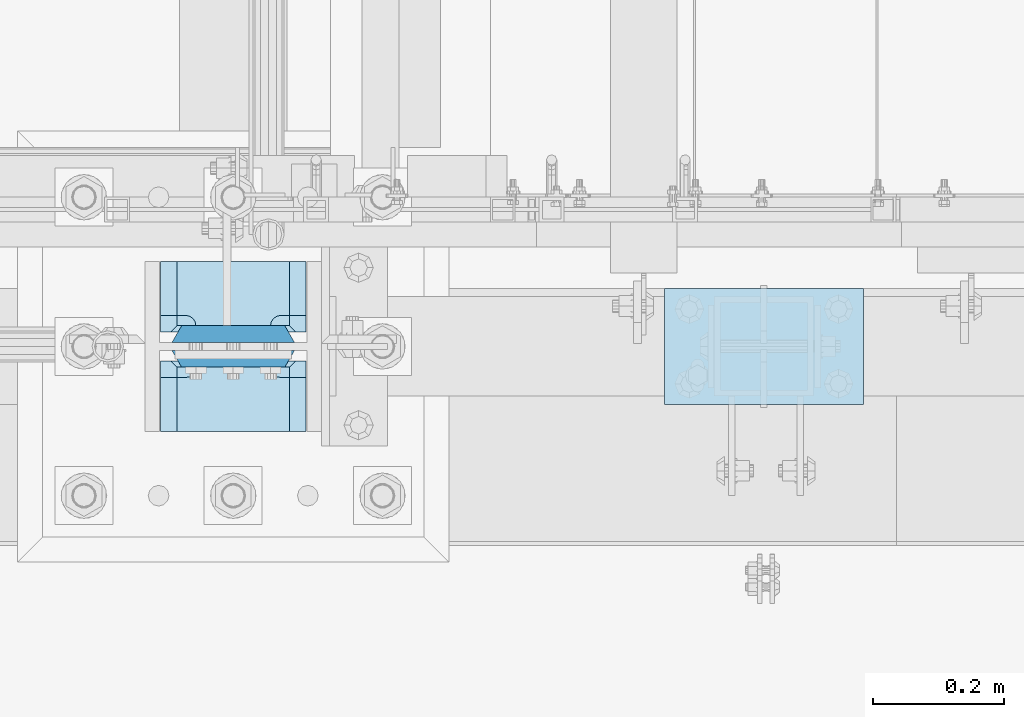
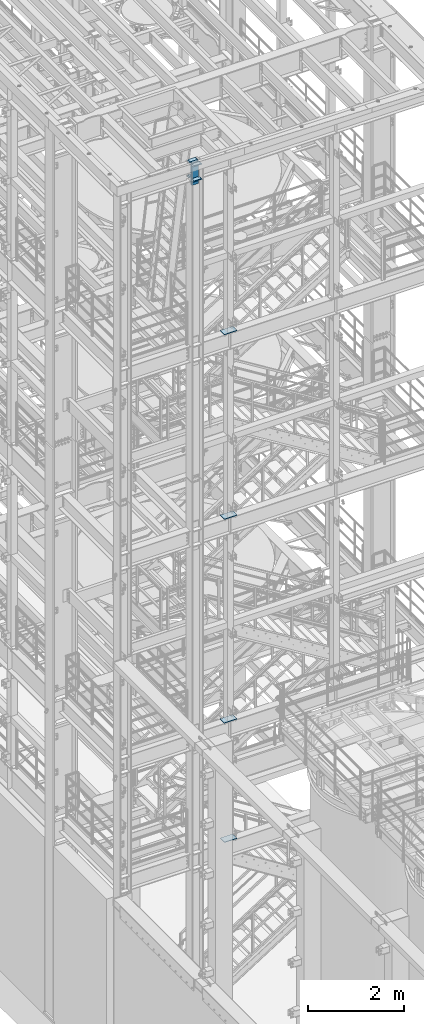
# One storey, part 1432 of 1876: 10 plates, 5 elements without a shape of their own.
"""IFC2X3 building model written with IfcOpenShell, lengths in millimetres."""

from ifc_helpers import new_model, si_unit, frame, origin_with_axes, place, context, subcontext, project, spatial, faceted_brep, material, type_object, element, aggregate, save


model = new_model("IFC2X3")

# Units and contexts
model_context = context("Model", 3, precision=1e-05, world=origin_with_axes())
body_context = subcontext(model_context, "Body", "Model", "MODEL_VIEW")
ifc_project = project(units=[si_unit("LENGTHUNIT", "METRE", prefix="MILLI"), si_unit("AREAUNIT", "SQUARE_METRE"), si_unit("VOLUMEUNIT", "CUBIC_METRE"), si_unit("MASSUNIT", "GRAM", prefix="KILO"), si_unit("TIMEUNIT", "SECOND"), si_unit("PLANEANGLEUNIT", "RADIAN"), si_unit("SOLIDANGLEUNIT", "STERADIAN"), si_unit("THERMODYNAMICTEMPERATUREUNIT", "DEGREE_CELSIUS"), si_unit("LUMINOUSINTENSITYUNIT", "LUMEN")], contexts=[model_context])

# Site, building, storey
site_placement = place(None, origin_with_axes())
site = spatial("IfcSite", under=ifc_project, at=site_placement, CompositionType="ELEMENT")
building_placement = place(site_placement, origin_with_axes())
building = spatial("IfcBuilding", under=site, at=building_placement, Name="Undefined", CompositionType="ELEMENT")
storey_placement = place(building_placement, origin_with_axes())
storey = spatial("IfcBuildingStorey", under=building, at=storey_placement, Name="Undefined", CompositionType="ELEMENT", Elevation=0.0)

# Assembly, plate
assembly_1_placement = place(storey_placement, origin_with_axes())
assembly_1 = element("IfcElementAssembly", 1, at=assembly_1_placement, inside=storey, Name="FRAME", AssemblyPlace="NOTDEFINED", PredefinedType="RIGID_FRAME")
ifc_material_1 = material(Name="STEEL/A36")
plate_type_1 = type_object("IfcPlateType", PredefinedType="NOTDEFINED")
plate_1_placement = place(assembly_1_placement, frame((2692.4, -7200.9, 17989.55), z_axis=(-1.0, 0.0, 0.0), x_axis=(0.0, 1.0, 0.0)))
plate_1 = element("IfcPlate", 2, at=plate_1_placement, type_object=plate_type_1, material=ifc_material_1, Name="PLATE", context=body_context, shape_type="Brep", body=[
    faceted_brep([(0.0, -6.35000000000036, 0.0), (0.0, -6.35000000000036, 304.799987792969), (0.0, 6.35000000000036, 304.799987792969), (0.0, 6.35000000000036, 0.0), (177.800003051758, -6.35000000000036, 304.799987792969), (177.800003051758, 6.35000000000036, 304.799987792969), (177.800003051758, -6.35000000000036, 0.0), (177.800003051758, 6.35000000000036, 0.0)], [[[0, 1, 2, 3]], [[1, 4, 5, 2]], [[4, 6, 7, 5]], [[6, 0, 3, 7]], [[5, 7, 3, 2]], [[6, 4, 1, 0]]]),
])
aggregate(assembly_1, [plate_1])

assembly_2_placement = place(storey_placement, origin_with_axes())
assembly_2 = element("IfcElementAssembly", 3, at=assembly_2_placement, inside=storey, Name="FRAME", AssemblyPlace="NOTDEFINED", PredefinedType="RIGID_FRAME")
plate_2_placement = place(assembly_2_placement, frame((2692.4, -7200.9, 13315.95), z_axis=(-1.0, 0.0, 0.0), x_axis=(0.0, 1.0, 0.0)))
plate_2 = element("IfcPlate", 4, at=plate_2_placement, type_object=plate_type_1, material=ifc_material_1, Name="PLATE", context=body_context, shape_type="Brep", body=[
    faceted_brep([(0.0, -6.35000000000036, 0.0), (0.0, -6.35000000000036, 304.799987792969), (0.0, 6.35000000000036, 304.799987792969), (0.0, 6.35000000000036, 0.0), (177.800003051758, -6.35000000000036, 304.799987792969), (177.800003051758, 6.35000000000036, 304.799987792969), (177.800003051758, -6.35000000000036, 0.0), (177.800003051758, 6.35000000000036, 0.0)], [[[0, 1, 2, 3]], [[1, 4, 5, 2]], [[4, 6, 7, 5]], [[6, 0, 3, 7]], [[5, 7, 3, 2]], [[6, 4, 1, 0]]]),
])
aggregate(assembly_2, [plate_2])

assembly_3_placement = place(storey_placement, origin_with_axes())
assembly_3 = element("IfcElementAssembly", 5, at=assembly_3_placement, inside=storey, Name="FRAME", AssemblyPlace="NOTDEFINED", PredefinedType="RIGID_FRAME")
plate_3_placement = place(assembly_3_placement, frame((2692.4, -7200.9, 8159.75), z_axis=(-1.0, 0.0, 0.0), x_axis=(0.0, 1.0, 0.0)))
plate_3 = element("IfcPlate", 6, at=plate_3_placement, type_object=plate_type_1, material=ifc_material_1, Name="PLATE", context=body_context, shape_type="Brep", body=[
    faceted_brep([(0.0, -6.35000000000036, 0.0), (0.0, -6.35000000000036, 304.799987792969), (0.0, 6.35000000000036, 304.799987792969), (0.0, 6.35000000000036, 0.0), (177.800003051758, -6.35000000000036, 304.799987792969), (177.800003051758, 6.35000000000036, 304.799987792969), (177.800003051758, -6.35000000000036, 0.0), (177.800003051758, 6.35000000000036, 0.0)], [[[0, 1, 2, 3]], [[1, 4, 5, 2]], [[4, 6, 7, 5]], [[6, 0, 3, 7]], [[5, 7, 3, 2]], [[6, 4, 1, 0]]]),
])
aggregate(assembly_3, [plate_3])

assembly_4_placement = place(storey_placement, origin_with_axes())
assembly_4 = element("IfcElementAssembly", 7, at=assembly_4_placement, inside=storey, Name="FRAME", AssemblyPlace="NOTDEFINED", PredefinedType="RIGID_FRAME")
plate_4_placement = place(assembly_4_placement, frame((2692.4, -7200.9, 5137.15), z_axis=(-1.0, 0.0, 0.0), x_axis=(0.0, 1.0, 0.0)))
plate_4 = element("IfcPlate", 8, at=plate_4_placement, type_object=plate_type_1, material=ifc_material_1, Name="PLATE", context=body_context, shape_type="Brep", body=[
    faceted_brep([(0.0, -6.35000000000036, 0.0), (0.0, -6.35000000000036, 304.799987792969), (0.0, 6.35000000000036, 304.799987792969), (0.0, 6.35000000000036, 0.0), (177.800003051758, -6.35000000000036, 304.799987792969), (177.800003051758, 6.35000000000036, 304.799987792969), (177.800003051758, -6.35000000000036, 0.0), (177.800003051758, 6.35000000000036, 0.0)], [[[0, 1, 2, 3]], [[1, 4, 5, 2]], [[4, 6, 7, 5]], [[6, 0, 3, 7]], [[5, 7, 3, 2]], [[6, 4, 1, 0]]]),
])
aggregate(assembly_4, [plate_4])

# Assembly, plates
assembly_5_placement = place(storey_placement, origin_with_axes())
assembly_5 = element("IfcElementAssembly", 9, at=assembly_5_placement, inside=storey, Name="COLUMN", AssemblyPlace="NOTDEFINED", PredefinedType="RIGID_FRAME")
ifc_material_2 = material(Name="STEEL/A572-50")
plate_type_2 = type_object("IfcPlateType", PredefinedType="NOTDEFINED")
plate_5_placement = place(assembly_5_placement, frame((1838.325, -7143.75, 22158.325012207), z_axis=(-1.0, 0.0, 0.0), x_axis=(0.0, -1.0, 0.0)))
plate_5 = element("IfcPlate", 10, at=plate_5_placement, type_object=plate_type_2, material=ifc_material_2, Name="PLATE", context=body_context, shape_type="Brep", body=[
    faceted_brep([(98.4250030517578, -12.7000000000007, 222.25), (98.4250030517578, 12.7000000000007, 197.150000002177), (15.875, 12.7000000000007, 197.150000002177), (15.875, -12.7000000000007, 222.25), (14.6665875786157, -12.7000000000007, 178.074902037082), (15.875, -12.7000000000007, 184.150001525879), (15.875, 12.7000000000007, 184.150001525879), (14.6665875786157, 12.7000000000007, 178.074902037082), (11.2253201513358, -12.7000000000007, 172.924681374541), (11.2253201513358, 12.7000000000007, 172.924681374541), (6.07509948879488, -12.7000000000007, 169.483413947261), (6.07509948879488, 12.7000000000007, 169.483413947261), (0.0, -12.7000000000007, 168.275001525879), (0.0, 12.7000000000007, 168.275001525879), (0.0, -12.7000000000007, 53.9749984741211), (0.0, 12.7000000000007, 53.9749984741211), (6.07509948879579, -12.7000000000007, 52.7665860527377), (6.07509948879579, 12.7000000000007, 52.7665860527377), (11.2253201513367, -12.7000000000007, 49.3253186254576), (11.2253201513367, 12.7000000000007, 49.3253186254576), (14.6665875786166, -12.7000000000007, 44.1750979629169), (14.6665875786166, 12.7000000000007, 44.1750979629169), (15.875, -12.7000000000007, 38.0999984741211), (15.875, 12.7000000000007, 38.0999984741211), (15.875, 12.7000000000007, 25.0999999978233), (15.875, -12.7000000000007, 0.0), (98.4250030517578, 12.7000000000007, 25.0999999978233), (98.4250030517578, -12.7000000000007, 0.0)], [[[0, 1, 2, 3]], [[4, 5, 6, 7]], [[8, 4, 7, 9]], [[10, 8, 9, 11]], [[12, 10, 11, 13]], [[14, 12, 13, 15]], [[16, 14, 15, 17]], [[18, 16, 17, 19]], [[20, 18, 19, 21]], [[22, 20, 21, 23]], [[22, 23, 24, 25]], [[26, 27, 25, 24]], [[5, 4, 8, 10, 12, 14, 16, 18, 20, 22, 25, 27, 0, 3]], [[6, 5, 3, 2]], [[26, 24, 23, 21, 19, 17, 15, 13, 11, 9, 7, 6, 2, 1]], [[27, 26, 1, 0]]]),
])
plate_6_placement = place(assembly_5_placement, frame((1838.325, -6981.825, 22158.325012207), z_axis=(-1.0, 0.0, 0.0), x_axis=(0.0, -1.0, 0.0)))
plate_6 = element("IfcPlate", 11, at=plate_6_placement, type_object=plate_type_2, material=ifc_material_2, Name="PLATE", context=body_context, shape_type="Brep", body=[
    faceted_brep([(82.5500030517578, -12.7000000000007, 222.25), (82.5500030517578, 12.7000000000007, 197.150000002177), (0.0, 12.7000000000007, 197.150000002177), (0.0, -12.7000000000007, 222.25), (82.5500030517578, 12.7000000000007, 25.0999999978233), (82.5500030517578, -12.7000000000007, 0.0), (0.0, -12.6999999999998, 0.0), (0.0, 12.7000000000007, 25.0999999978233), (82.5500030517578, 12.7000000000007, 38.0999984741211), (82.5500030517578, -12.7000000000007, 38.0999984741211), (83.7584154731412, -12.7000000000007, 44.1750979629169), (83.7584154731412, 12.7000000000007, 44.1750979629169), (87.1996829004211, -12.7000000000007, 49.3253186254576), (87.1996829004211, 12.7000000000007, 49.3253186254576), (92.349903562962, -12.7000000000007, 52.7665860527377), (92.349903562962, 12.7000000000007, 52.7665860527377), (98.4250030517578, -12.7000000000007, 53.9749984741211), (98.4250030517578, 12.7000000000007, 53.9749984741211), (98.4250030517578, -12.7000000000007, 168.275001525879), (98.4250030517578, 12.7000000000007, 168.275001525879), (92.349903562962, -12.7000000000007, 169.483413947262), (92.349903562962, 12.7000000000007, 169.483413947262), (87.1996829004211, -12.7000000000007, 172.924681374543), (87.1996829004211, 12.7000000000007, 172.924681374543), (83.7584154731412, -12.7000000000007, 178.074902037083), (83.7584154731412, 12.7000000000007, 178.074902037083), (82.5500030517578, -12.7000000000007, 184.150001525879), (82.5500030517578, 12.7000000000007, 184.150001525879)], [[[0, 1, 2, 3]], [[4, 5, 6, 7]], [[8, 9, 5, 4]], [[10, 9, 8, 11]], [[12, 10, 11, 13]], [[14, 12, 13, 15]], [[16, 14, 15, 17]], [[18, 16, 17, 19]], [[20, 18, 19, 21]], [[22, 20, 21, 23]], [[24, 22, 23, 25]], [[26, 24, 25, 27]], [[6, 5, 9, 10, 12, 14, 16, 18, 20, 22, 24, 26, 0, 3]], [[7, 6, 3, 2]], [[27, 25, 23, 21, 19, 17, 15, 13, 11, 8, 4, 7, 2, 1]], [[26, 27, 1, 0]]]),
])
ifc_material_3 = material(Name="STEEL/A572-GR.50")
plate_type_3 = type_object("IfcPlateType", PredefinedType="NOTDEFINED")
plate_7_placement = place(assembly_5_placement, frame((1633.5375, -7092.95, 22529.8), z_axis=(1.0, 0.0, 0.0), x_axis=(0.0, 0.0, -1.0)))
plate_7 = element("IfcPlate", 12, at=plate_7_placement, type_object=plate_type_3, material=ifc_material_3, Name="PLATE", context=body_context, shape_type="Brep", body=[
    faceted_brep([(0.0, 12.6999999999998, 172.66030316161), (0.0, -12.6999999999998, 187.324996948242), (536.575012207031, -12.6999999999998, 187.324996948242), (536.575012207031, 12.6999999999998, 172.66030316161), (536.575012207031, 12.6999999999998, 14.6646968383725), (0.0, 12.6999999999998, 14.6646968383725), (0.0, -12.6999999999998, 0.0), (536.575012207031, -12.6999999999998, 0.0)], [[[0, 1, 2, 3]], [[0, 3, 4, 5]], [[1, 0, 5, 6]], [[2, 1, 6, 7]], [[3, 2, 7, 4]], [[6, 5, 4, 7]]]),
])
plate_8_placement = place(assembly_5_placement, frame((1633.5375, -7131.05, 22529.8), z_axis=(1.0, 0.0, 0.0), x_axis=(0.0, 0.0, -1.0)))
plate_8 = element("IfcPlate", 13, at=plate_8_placement, type_object=plate_type_3, material=ifc_material_3, Name="PLATE", context=body_context, shape_type="Brep", body=[
    faceted_brep([(0.0, -12.6999999999998, 172.660303166218), (536.575012207031, -12.6999999999998, 172.660303166218), (536.575012207031, 12.6999999999998, 187.324996948242), (0.0, 12.6999999999998, 187.324996948242), (536.575012207031, -12.6999999999998, 14.6646968337648), (536.575012207031, 12.6999999999998, 0.0), (0.0, 12.6999999999998, 0.0), (0.0, -12.6999999999998, 14.6646968337648)], [[[0, 1, 2, 3]], [[2, 1, 4, 5]], [[3, 2, 5, 6]], [[0, 3, 6, 7]], [[1, 0, 7, 4]], [[6, 5, 4, 7]]]),
])
plate_type_4 = type_object("IfcPlateType", PredefinedType="NOTDEFINED")
plate_9_placement = place(assembly_5_placement, frame((1838.325, -7118.35, 22542.5), z_axis=(-1.0, 0.0, 0.0), x_axis=(0.0, -1.0, 0.0)))
plate_9 = element("IfcPlate", 14, at=plate_9_placement, type_object=plate_type_4, material=ifc_material_2, Name="PLATE", context=body_context, shape_type="Brep", body=[
    faceted_brep([(123.824996948242, -12.5499999989115, 222.40000000109), (123.824996948242, 12.7000000000007, 197.15000000218), (25.4000000000024, 12.7000000000007, 197.15000000218), (15.875, 3.17499999999563, 206.675000002184), (15.875, -12.7000000000007, 222.25), (14.6665875786157, -12.7000000000007, 178.074902037082), (15.875, -12.7000000000007, 184.150001525879), (15.875, 3.17499999999563, 184.150001525879), (14.6665875786157, 1.96658757861223, 178.074902037082), (11.2253201513358, -12.7000000000007, 172.924681374541), (11.2253201513358, -1.47467984866671, 172.924681374541), (6.07509948879488, -12.7000000000007, 169.483413947261), (6.07509948879488, -6.62490051120767, 169.483413947261), (0.0, -12.7000000000007, 168.275001525879), (6.07509948879579, -12.7000000000007, 52.7665860527377), (0.0, -12.7000000000007, 53.9749984741211), (6.07509948879579, -6.62490051120767, 52.7665860527377), (11.2253201513367, -12.7000000000007, 49.3253186254576), (11.2253201513367, -1.47467984866671, 49.3253186254576), (14.6665875786166, -12.7000000000007, 44.1750979629169), (14.6665875786166, 1.96658757861223, 44.1750979629169), (15.875, -12.7000000000007, 38.0999984741211), (15.875, 3.17499999999563, 38.0999984741211), (15.875, 3.17499999999563, 15.6499999983591), (15.875, -12.7000000000007, 0.0), (123.824996948242, 12.7000000000007, 25.1749999983624), (123.824996948242, -12.7000000000007, 0.0), (25.4000000000024, 12.7000000000007, 25.1749999983624)], [[[0, 1, 2, 3, 4]], [[5, 6, 7, 8]], [[9, 5, 8, 10]], [[11, 9, 10, 12]], [[11, 12, 13]], [[14, 15, 16]], [[17, 14, 16, 18]], [[19, 17, 18, 20]], [[21, 19, 20, 22]], [[21, 22, 23, 24]], [[25, 26, 24, 23, 27]], [[6, 5, 9, 11, 13, 15, 14, 17, 19, 21, 24, 26, 0, 4]], [[7, 6, 4, 3]], [[27, 23, 22, 20, 18, 16, 15, 13, 12, 10, 8, 7, 3, 2]], [[25, 27, 2, 1]], [[26, 25, 1, 0]]]),
])
plate_10_placement = place(assembly_5_placement, frame((1838.325, -6981.825, 22542.5), z_axis=(-1.0, 0.0, 0.0), x_axis=(0.0, -1.0, 0.0)))
plate_10 = element("IfcPlate", 15, at=plate_10_placement, type_object=plate_type_4, material=ifc_material_2, Name="PLATE", context=body_context, shape_type="Brep", body=[
    faceted_brep([(107.950004577637, -12.7000000000007, 222.25), (107.950004577637, 3.17499829605367, 206.675001706127), (98.4250030517578, 12.7000000000007, 197.150000002177), (0.0, 12.7000000000007, 197.150000002177), (0.0, -12.7000000000007, 222.25), (107.950004577637, 3.17499829605367, 15.5749982938728), (107.950004577637, -12.7000000000007, 0.0), (0.0, -12.6999999999998, 0.0), (0.0, 12.7000000000007, 25.0999999978233), (98.4250030517578, 12.7000000000007, 25.0999999978233), (107.950004577637, 3.17499829605367, 38.0999984741211), (107.950004577637, -12.7000000000007, 38.0999984741211), (109.15841699902, -12.7000000000007, 44.1750979629169), (109.15841699902, 1.96658565592224, 44.1750979629169), (112.5996844263, -12.7000000000007, 49.3253186254576), (112.5996844263, -1.47468239429145, 49.3253186254576), (117.749905088841, -12.7000000000007, 52.7665860527377), (117.749905088841, -6.62490398912269, 52.7665860527377), (123.825004577637, -12.7000000000007, 53.9749984741211), (117.749905088841, -12.7000000000007, 169.483413947262), (123.825004577637, -12.7000000000007, 168.275001525879), (117.749905088841, -6.62490398912269, 169.483413947262), (112.5996844263, -12.7000000000007, 172.924681374543), (112.5996844263, -1.47468239429145, 172.924681374543), (109.15841699902, -12.7000000000007, 178.074902037083), (109.15841699902, 1.96658565592588, 178.074902037083), (107.950004577637, -12.7000000000007, 184.150001525879), (107.950004577637, 3.17499829605367, 184.150001525879)], [[[0, 1, 2, 3, 4]], [[5, 6, 7, 8, 9]], [[10, 11, 6, 5]], [[12, 11, 10, 13]], [[14, 12, 13, 15]], [[16, 14, 15, 17]], [[16, 17, 18]], [[19, 20, 21]], [[22, 19, 21, 23]], [[24, 22, 23, 25]], [[26, 24, 25, 27]], [[7, 6, 11, 12, 14, 16, 18, 20, 19, 22, 24, 26, 0, 4]], [[8, 7, 4, 3]], [[9, 8, 3, 2]], [[27, 25, 23, 21, 20, 18, 17, 15, 13, 10, 5, 9, 2, 1]], [[26, 27, 1, 0]]]),
])
aggregate(assembly_5, [plate_5, plate_6, plate_7, plate_8, plate_9, plate_10])

save(model, "model.ifc")
